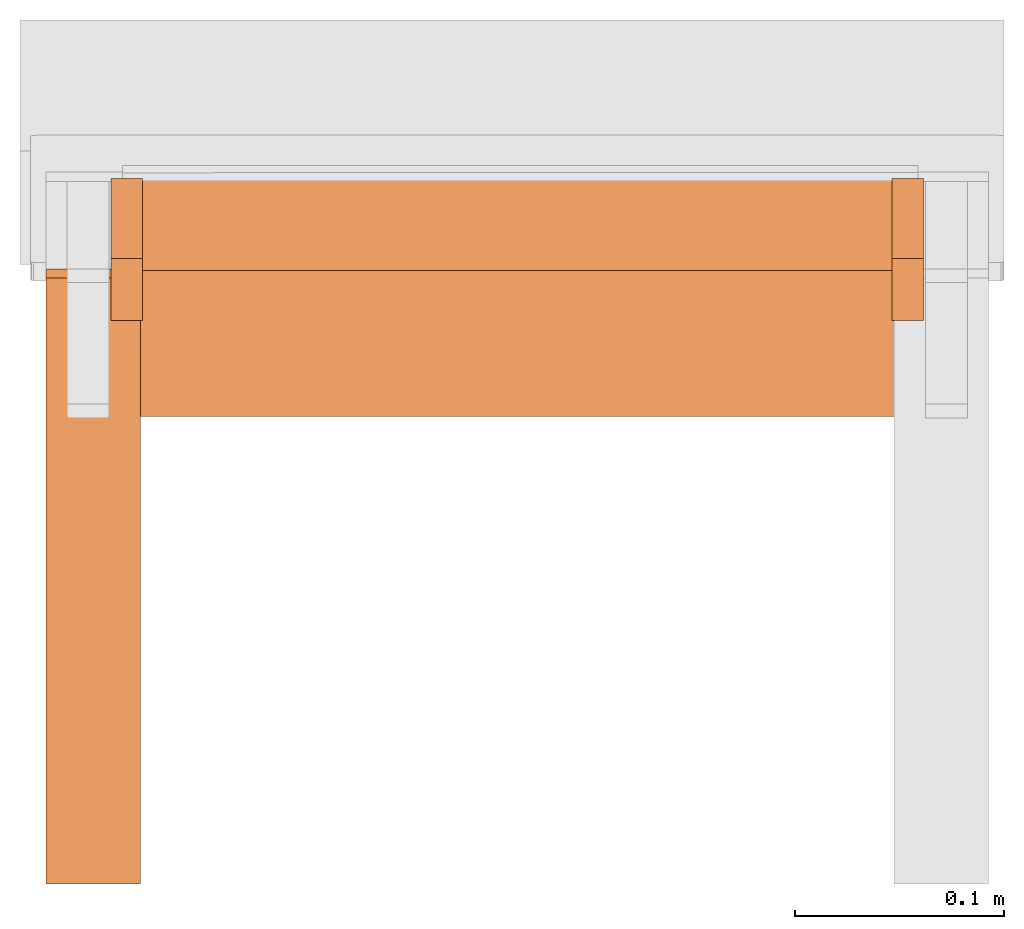
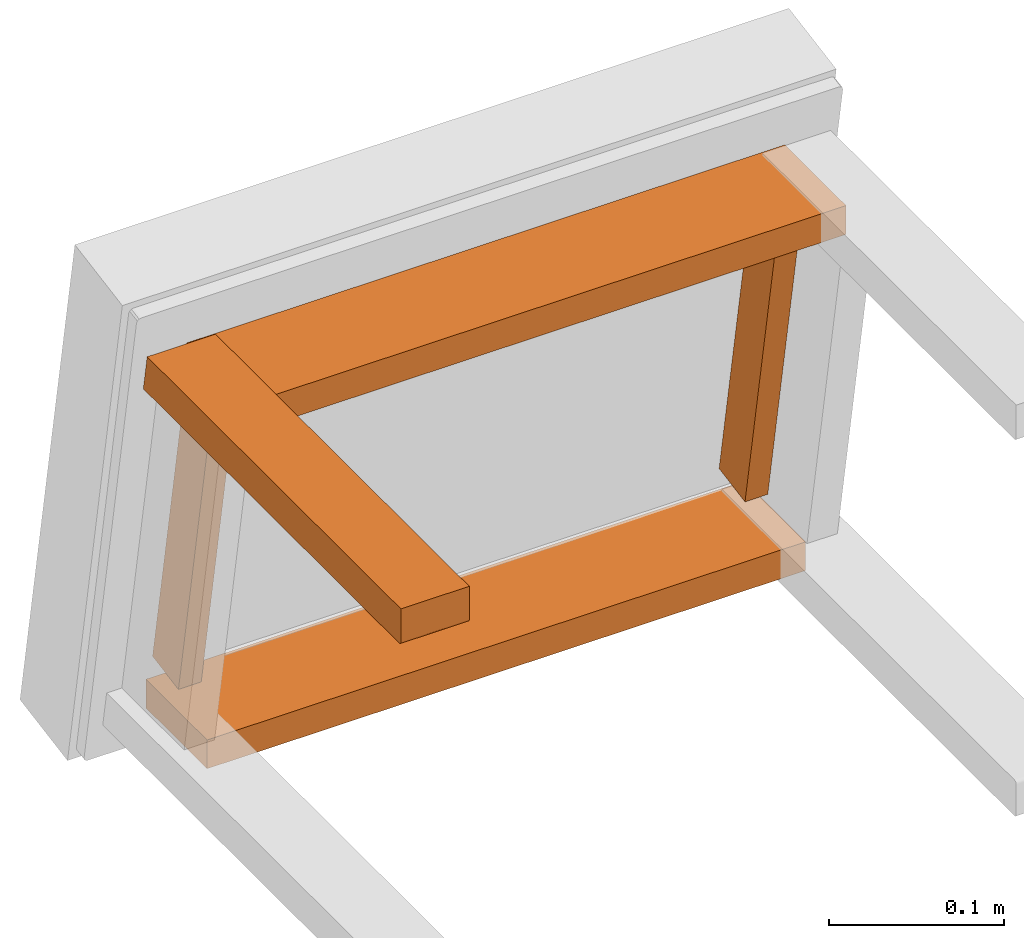
# One storey, part 1 of 5: 5 proxies, 1 element without a shape of its own.
"""IFC2X3 building model written with IfcOpenShell, lengths in metres."""

from ifc_helpers import new_model, si_unit, direction, origin_with_axes, place, context, project, spatial, faceted_brep, source, transform, mapped, element, aggregate, save


model = new_model("IFC2X3")

# Units and contexts
model_context = context("Model", 3, precision=1e-06, world=origin_with_axes(), true_north=direction((0.0, 1.0, 0.0)))
ifc_project = project(units=[si_unit("LENGTHUNIT", "METRE"), si_unit("AREAUNIT", "SQUARE_METRE"), si_unit("VOLUMEUNIT", "CUBIC_METRE")], contexts=[model_context])

# Site, building, storey
site_placement = place(None, origin_with_axes())
site = spatial("IfcSite", under=ifc_project, at=site_placement, CompositionType="ELEMENT")
building_placement = place(site_placement, origin_with_axes())
building = spatial("IfcBuilding", under=site, at=building_placement, Name="Default Building", CompositionType="ELEMENT")
storey_placement = place(building_placement, origin_with_axes())
storey = spatial("IfcBuildingStorey", under=building, at=storey_placement, Name="Default Storey", CompositionType="ELEMENT", Elevation=0.0)

# Assembly, proxies
assembly_placement = place(storey_placement, origin_with_axes())
assembly = element("IfcElementAssembly", 1, at=assembly_placement, inside=storey, Name="Pan H-68-037-A-REV reduced", ObjectType="Pan H-68-037-A-REV reduced", AssemblyPlace="NOTDEFINED", PredefinedType="NOTDEFINED")
shared_shape_1 = source(origin_with_axes(), model_context, "Body", "Brep", [
    faceted_brep([(0.19699999690055847, -0.08120664209127426, 0.25200098752975464), (0.19699999690055847, -0.08120664209127426, 0.2720009982585907), (-0.19699999690055847, -0.08120664209127426, 0.25200098752975464), (-0.19699999690055847, -0.08120664209127426, 0.25200098752975464), (0.19699999690055847, -0.08120664209127426, 0.2720009982585907), (-0.19699999690055847, -0.08120664209127426, 0.2720009982585907), (0.19699999690055847, -0.011398392729461193, 0.25200098752975464), (0.19699999690055847, -0.08120664209127426, 0.25200098752975464), (-0.19699999690055847, -0.011398392729461193, 0.25200098752975464), (-0.19699999690055847, -0.011398392729461193, 0.25200098752975464), (0.19699999690055847, -0.08120664209127426, 0.25200098752975464), (-0.19699999690055847, -0.08120664209127426, 0.25200098752975464), (0.19699999690055847, -0.011398392729461193, 0.2720009982585907), (0.19699999690055847, -0.011398392729461193, 0.25200098752975464), (-0.19699999690055847, -0.011398392729461193, 0.2720009982585907), (-0.19699999690055847, -0.011398392729461193, 0.2720009982585907), (0.19699999690055847, -0.011398392729461193, 0.25200098752975464), (-0.19699999690055847, -0.011398392729461193, 0.25200098752975464), (0.19699999690055847, -0.08120664209127426, 0.2720009982585907), (0.19699999690055847, -0.011398392729461193, 0.2720009982585907), (-0.19699999690055847, -0.08120664209127426, 0.2720009982585907), (-0.19699999690055847, -0.08120664209127426, 0.2720009982585907), (0.19699999690055847, -0.011398392729461193, 0.2720009982585907), (-0.19699999690055847, -0.011398392729461193, 0.2720009982585907), (0.19699999690055847, -0.011398392729461193, 0.25200098752975464), (0.19699999690055847, -0.011398392729461193, 0.2720009982585907), (0.19699999690055847, -0.08120664209127426, 0.25200098752975464), (0.19699999690055847, -0.08120664209127426, 0.25200098752975464), (0.19699999690055847, -0.011398392729461193, 0.2720009982585907), (0.19699999690055847, -0.08120664209127426, 0.2720009982585907), (-0.19699999690055847, -0.011398392729461193, 0.2720009982585907), (-0.19699999690055847, -0.011398392729461193, 0.25200098752975464), (-0.19699999690055847, -0.08120664209127426, 0.2720009982585907), (-0.19699999690055847, -0.08120664209127426, 0.2720009982585907), (-0.19699999690055847, -0.011398392729461193, 0.25200098752975464), (-0.19699999690055847, -0.08120664209127426, 0.25200098752975464)], [[[0, 1, 2]], [[3, 4, 5]], [[6, 7, 8]], [[9, 10, 11]], [[12, 13, 14]], [[15, 16, 17]], [[18, 19, 20]], [[21, 22, 23]], [[24, 25, 26]], [[27, 28, 29]], [[30, 31, 32]], [[33, 34, 35]]]),
])
proxy_1_placement = place(assembly_placement, origin_with_axes())
proxy_1 = element("IfcBuildingElementProxy", 2, at=proxy_1_placement, Name="9", ObjectType="9", CompositionType="ELEMENT", context=model_context, shape_type="MappedRepresentation", body=[
    mapped(shared_shape_1, transform((0.0, 0.0, 0.0), scale=1.0)),
])
shared_shape_2 = source(origin_with_axes(), model_context, "Body", "Brep", [
    faceted_brep([(-0.19699999690055847, -0.03500000014901161, 0.009999999776482582), (-0.19699999690055847, -0.03500000014901161, -0.009999999776482582), (0.19699999690055847, -0.03500000014901161, 0.009999999776482582), (0.19699999690055847, -0.03500000014901161, 0.009999999776482582), (-0.19699999690055847, -0.03500000014901161, -0.009999999776482582), (0.19699999690055847, -0.03500000014901161, -0.009999999776482582), (-0.19699999690055847, 0.03480824455618858, 0.009999999776482582), (-0.19699999690055847, -0.03500000014901161, 0.009999999776482582), (0.19699999690055847, 0.03480824455618858, 0.009999999776482582), (0.19699999690055847, 0.03480824455618858, 0.009999999776482582), (-0.19699999690055847, -0.03500000014901161, 0.009999999776482582), (0.19699999690055847, -0.03500000014901161, 0.009999999776482582), (-0.19699999690055847, 0.03480824455618858, -0.009999999776482582), (-0.19699999690055847, 0.03480824455618858, 0.009999999776482582), (0.19699999690055847, 0.03480824455618858, -0.009999999776482582), (0.19699999690055847, 0.03480824455618858, -0.009999999776482582), (-0.19699999690055847, 0.03480824455618858, 0.009999999776482582), (0.19699999690055847, 0.03480824455618858, 0.009999999776482582), (-0.19699999690055847, -0.03500000014901161, -0.009999999776482582), (-0.19699999690055847, 0.03480824455618858, -0.009999999776482582), (0.19699999690055847, -0.03500000014901161, -0.009999999776482582), (0.19699999690055847, -0.03500000014901161, -0.009999999776482582), (-0.19699999690055847, 0.03480824455618858, -0.009999999776482582), (0.19699999690055847, 0.03480824455618858, -0.009999999776482582), (-0.19699999690055847, 0.03480824455618858, 0.009999999776482582), (-0.19699999690055847, 0.03480824455618858, -0.009999999776482582), (-0.19699999690055847, -0.03500000014901161, 0.009999999776482582), (-0.19699999690055847, -0.03500000014901161, 0.009999999776482582), (-0.19699999690055847, 0.03480824455618858, -0.009999999776482582), (-0.19699999690055847, -0.03500000014901161, -0.009999999776482582), (0.19699999690055847, 0.03480824455618858, -0.009999999776482582), (0.19699999690055847, 0.03480824455618858, 0.009999999776482582), (0.19699999690055847, -0.03500000014901161, -0.009999999776482582), (0.19699999690055847, -0.03500000014901161, -0.009999999776482582), (0.19699999690055847, 0.03480824455618858, 0.009999999776482582), (0.19699999690055847, -0.03500000014901161, 0.009999999776482582)], [[[0, 1, 2]], [[3, 4, 5]], [[6, 7, 8]], [[9, 10, 11]], [[12, 13, 14]], [[15, 16, 17]], [[18, 19, 20]], [[21, 22, 23]], [[24, 25, 26]], [[27, 28, 29]], [[30, 31, 32]], [[33, 34, 35]]]),
])
proxy_2_placement = place(assembly_placement, origin_with_axes())
proxy_2 = element("IfcBuildingElementProxy", 3, at=proxy_2_placement, Name="10", ObjectType="10", CompositionType="ELEMENT", context=model_context, shape_type="MappedRepresentation", body=[
    mapped(shared_shape_2, transform((0.0, 0.0, 0.0), scale=1.0)),
])
shared_shape_3 = source(origin_with_axes(), model_context, "Body", "Brep", [
    faceted_brep([(0.17898231744766235, 0.002902057720348239, 0.021152222529053688), (0.1939823180437088, 0.002902057720348239, 0.021152222529053688), (0.17898231744766235, -0.035300541669130325, 0.2378099262714386), (0.17898231744766235, -0.035300541669130325, 0.2378099262714386), (0.1939823180437088, 0.002902057720348239, 0.021152222529053688), (0.1939823180437088, -0.035300541669130325, 0.2378099262714386), (0.17898231744766235, 0.03244629129767418, 0.02636166848242283), (0.17898231744766235, 0.002902057720348239, 0.021152222529053688), (0.17898231744766235, -0.005756308790296316, 0.24301937222480774), (0.17898231744766235, -0.005756308790296316, 0.24301937222480774), (0.17898231744766235, 0.002902057720348239, 0.021152222529053688), (0.17898231744766235, -0.035300541669130325, 0.2378099262714386), (0.1939823180437088, 0.03244629129767418, 0.02636166848242283), (0.17898231744766235, 0.03244629129767418, 0.02636166848242283), (0.1939823180437088, -0.005756308790296316, 0.24301937222480774), (0.1939823180437088, -0.005756308790296316, 0.24301937222480774), (0.17898231744766235, 0.03244629129767418, 0.02636166848242283), (0.17898231744766235, -0.005756308790296316, 0.24301937222480774), (0.1939823180437088, 0.002902057720348239, 0.021152222529053688), (0.1939823180437088, 0.03244629129767418, 0.02636166848242283), (0.1939823180437088, -0.035300541669130325, 0.2378099262714386), (0.1939823180437088, -0.035300541669130325, 0.2378099262714386), (0.1939823180437088, 0.03244629129767418, 0.02636166848242283), (0.1939823180437088, -0.005756308790296316, 0.24301937222480774), (0.17898231744766235, 0.03244629129767418, 0.02636166848242283), (0.1939823180437088, 0.03244629129767418, 0.02636166848242283), (0.17898231744766235, 0.002902057720348239, 0.021152222529053688), (0.17898231744766235, 0.002902057720348239, 0.021152222529053688), (0.1939823180437088, 0.03244629129767418, 0.02636166848242283), (0.1939823180437088, 0.002902057720348239, 0.021152222529053688), (0.1939823180437088, -0.005756308790296316, 0.24301937222480774), (0.17898231744766235, -0.005756308790296316, 0.24301937222480774), (0.1939823180437088, -0.035300541669130325, 0.2378099262714386), (0.1939823180437088, -0.035300541669130325, 0.2378099262714386), (0.17898231744766235, -0.005756308790296316, 0.24301937222480774), (0.17898231744766235, -0.035300541669130325, 0.2378099262714386)], [[[0, 1, 2]], [[3, 4, 5]], [[6, 7, 8]], [[9, 10, 11]], [[12, 13, 14]], [[15, 16, 17]], [[18, 19, 20]], [[21, 22, 23]], [[24, 25, 26]], [[27, 28, 29]], [[30, 31, 32]], [[33, 34, 35]]]),
])
proxy_3_placement = place(assembly_placement, origin_with_axes())
proxy_3 = element("IfcBuildingElementProxy", 4, at=proxy_3_placement, Name="11", ObjectType="11", CompositionType="ELEMENT", context=model_context, shape_type="MappedRepresentation", body=[
    mapped(shared_shape_3, transform((0.0, 0.0, 0.0), scale=1.0)),
])
shared_shape_4 = source(origin_with_axes(), model_context, "Body", "Brep", [
    faceted_brep([(-0.1939823180437088, 0.002902057720348239, 0.021152222529053688), (-0.17898231744766235, 0.002902057720348239, 0.021152222529053688), (-0.1939823180437088, -0.035300541669130325, 0.2378099262714386), (-0.1939823180437088, -0.035300541669130325, 0.2378099262714386), (-0.17898231744766235, 0.002902057720348239, 0.021152222529053688), (-0.17898231744766235, -0.035300541669130325, 0.2378099262714386), (-0.1939823180437088, 0.03244629129767418, 0.02636166848242283), (-0.1939823180437088, 0.002902057720348239, 0.021152222529053688), (-0.1939823180437088, -0.005756308790296316, 0.24301937222480774), (-0.1939823180437088, -0.005756308790296316, 0.24301937222480774), (-0.1939823180437088, 0.002902057720348239, 0.021152222529053688), (-0.1939823180437088, -0.035300541669130325, 0.2378099262714386), (-0.17898231744766235, 0.03244629129767418, 0.02636166848242283), (-0.1939823180437088, 0.03244629129767418, 0.02636166848242283), (-0.17898231744766235, -0.005756308790296316, 0.24301937222480774), (-0.17898231744766235, -0.005756308790296316, 0.24301937222480774), (-0.1939823180437088, 0.03244629129767418, 0.02636166848242283), (-0.1939823180437088, -0.005756308790296316, 0.24301937222480774), (-0.17898231744766235, 0.002902057720348239, 0.021152222529053688), (-0.17898231744766235, 0.03244629129767418, 0.02636166848242283), (-0.17898231744766235, -0.035300541669130325, 0.2378099262714386), (-0.17898231744766235, -0.035300541669130325, 0.2378099262714386), (-0.17898231744766235, 0.03244629129767418, 0.02636166848242283), (-0.17898231744766235, -0.005756308790296316, 0.24301937222480774), (-0.1939823180437088, 0.03244629129767418, 0.02636166848242283), (-0.17898231744766235, 0.03244629129767418, 0.02636166848242283), (-0.1939823180437088, 0.002902057720348239, 0.021152222529053688), (-0.1939823180437088, 0.002902057720348239, 0.021152222529053688), (-0.17898231744766235, 0.03244629129767418, 0.02636166848242283), (-0.17898231744766235, 0.002902057720348239, 0.021152222529053688), (-0.17898231744766235, -0.005756308790296316, 0.24301937222480774), (-0.1939823180437088, -0.005756308790296316, 0.24301937222480774), (-0.17898231744766235, -0.035300541669130325, 0.2378099262714386), (-0.17898231744766235, -0.035300541669130325, 0.2378099262714386), (-0.1939823180437088, -0.005756308790296316, 0.24301937222480774), (-0.1939823180437088, -0.035300541669130325, 0.2378099262714386)], [[[0, 1, 2]], [[3, 4, 5]], [[6, 7, 8]], [[9, 10, 11]], [[12, 13, 14]], [[15, 16, 17]], [[18, 19, 20]], [[21, 22, 23]], [[24, 25, 26]], [[27, 28, 29]], [[30, 31, 32]], [[33, 34, 35]]]),
])
proxy_4_placement = place(assembly_placement, origin_with_axes())
proxy_4 = element("IfcBuildingElementProxy", 5, at=proxy_4_placement, Name="12", ObjectType="12", CompositionType="ELEMENT", context=model_context, shape_type="MappedRepresentation", body=[
    mapped(shared_shape_4, transform((0.0, 0.0, 0.0), scale=1.0)),
])
shared_shape_5 = source(origin_with_axes(), model_context, "Body", "Brep", [
    faceted_brep([(-0.22499999403953552, -0.014805259183049202, 0.27250099182128906), (-0.22499999403953552, -0.015157913789153099, 0.2745009958744049), (-0.18000000715255737, -0.014805259183049202, 0.27250099182128906), (-0.18000000715255737, -0.014805259183049202, 0.27250099182128906), (-0.22499999403953552, -0.015157913789153099, 0.2745009958744049), (-0.18000000715255737, -0.015157913789153099, 0.2745009958744049), (-0.22499999403953552, -0.015157913789153099, 0.2745009958744049), (-0.22499999403953552, -0.09570664912462234, 0.2745009958744049), (-0.18000000715255737, -0.015157913789153099, 0.2745009958744049), (-0.18000000715255737, -0.015157913789153099, 0.2745009958744049), (-0.22499999403953552, -0.09570664912462234, 0.2745009958744049), (-0.18000000715255737, -0.09570664912462234, 0.2745009958744049), (-0.22499999403953552, -0.09570664912462234, 0.2745009958744049), (-0.22499999403953552, -0.3045358955860138, 0.2745009958744049), (-0.18000000715255737, -0.09570664912462234, 0.2745009958744049), (-0.18000000715255737, -0.09570664912462234, 0.2745009958744049), (-0.22499999403953552, -0.3045358955860138, 0.2745009958744049), (-0.18000000715255737, -0.3045358955860138, 0.2745009958744049), (-0.22499999403953552, -0.3045358955860138, 0.2745009958744049), (-0.22499999403953552, -0.3045358955860138, 0.2515009939670563), (-0.18000000715255737, -0.3045358955860138, 0.2745009958744049), (-0.18000000715255737, -0.3045358955860138, 0.2745009958744049), (-0.22499999403953552, -0.3045358955860138, 0.2515009939670563), (-0.18000000715255737, -0.3045358955860138, 0.2515009939670563), (-0.22499999403953552, -0.30253592133522034, 0.24950098991394043), (-0.18000000715255737, -0.30253592133522034, 0.24950098991394043), (-0.18000000715255737, -0.3030535578727722, 0.2495691329240799), (-0.22499999403953552, -0.30253592133522034, 0.24950098991394043), (-0.18000000715255737, -0.3030535578727722, 0.2495691329240799), (-0.22499999403953552, -0.3030535578727722, 0.2495691329240799), (-0.22499999403953552, -0.3030535578727722, 0.2495691329240799), (-0.18000000715255737, -0.3030535578727722, 0.2495691329240799), (-0.18000000715255737, -0.30353590846061707, 0.2497689425945282), (-0.22499999403953552, -0.3030535578727722, 0.2495691329240799), (-0.18000000715255737, -0.30353590846061707, 0.2497689425945282), (-0.22499999403953552, -0.30353590846061707, 0.2497689425945282), (-0.22499999403953552, -0.30353590846061707, 0.2497689425945282), (-0.18000000715255737, -0.30353590846061707, 0.2497689425945282), (-0.18000000715255737, -0.30395013093948364, 0.25008678436279297), (-0.22499999403953552, -0.30353590846061707, 0.2497689425945282), (-0.18000000715255737, -0.30395013093948364, 0.25008678436279297), (-0.22499999403953552, -0.30395013093948364, 0.25008678436279297), (-0.22499999403953552, -0.30395013093948364, 0.25008678436279297), (-0.18000000715255737, -0.30395013093948364, 0.25008678436279297), (-0.18000000715255737, -0.3042679727077484, 0.25050097703933716), (-0.22499999403953552, -0.30395013093948364, 0.25008678436279297), (-0.18000000715255737, -0.3042679727077484, 0.25050097703933716), (-0.22499999403953552, -0.3042679727077484, 0.25050097703933716), (-0.22499999403953552, -0.3042679727077484, 0.25050097703933716), (-0.18000000715255737, -0.3042679727077484, 0.25050097703933716), (-0.18000000715255737, -0.3044677674770355, 0.2509833574295044), (-0.22499999403953552, -0.3042679727077484, 0.25050097703933716), (-0.18000000715255737, -0.3044677674770355, 0.2509833574295044), (-0.22499999403953552, -0.3044677674770355, 0.2509833574295044), (-0.22499999403953552, -0.3044677674770355, 0.2509833574295044), (-0.18000000715255737, -0.3044677674770355, 0.2509833574295044), (-0.18000000715255737, -0.3045358955860138, 0.2515009939670563), (-0.22499999403953552, -0.3044677674770355, 0.2509833574295044), (-0.18000000715255737, -0.3045358955860138, 0.2515009939670563), (-0.22499999403953552, -0.3045358955860138, 0.2515009939670563), (-0.22499999403953552, -0.30253592133522034, 0.24950098991394043), (-0.22499999403953552, -0.09570664912462234, 0.24950098991394043), (-0.18000000715255737, -0.30253592133522034, 0.24950098991394043), (-0.18000000715255737, -0.30253592133522034, 0.24950098991394043), (-0.22499999403953552, -0.09570664912462234, 0.24950098991394043), (-0.18000000715255737, -0.09570664912462234, 0.24950098991394043), (-0.22499999403953552, -0.09570664912462234, 0.24950098991394043), (-0.22499999403953552, -0.010749738663434982, 0.24950098991394043), (-0.18000000715255737, -0.09570664912462234, 0.24950098991394043), (-0.18000000715255737, -0.09570664912462234, 0.24950098991394043), (-0.22499999403953552, -0.010749738663434982, 0.24950098991394043), (-0.18000000715255737, -0.010749738663434982, 0.24950098991394043), (-0.22499999403953552, -0.010749738663434982, 0.24950098991394043), (-0.22499999403953552, -0.011102392338216305, 0.2515009939670563), (-0.18000000715255737, -0.010749738663434982, 0.24950098991394043), (-0.18000000715255737, -0.010749738663434982, 0.24950098991394043), (-0.22499999403953552, -0.011102392338216305, 0.2515009939670563), (-0.18000000715255737, -0.011102392338216305, 0.2515009939670563), (-0.22499999403953552, -0.011102392338216305, 0.2515009939670563), (-0.22499999403953552, -0.014805259183049202, 0.27250099182128906), (-0.18000000715255737, -0.011102392338216305, 0.2515009939670563), (-0.18000000715255737, -0.011102392338216305, 0.2515009939670563), (-0.22499999403953552, -0.014805259183049202, 0.27250099182128906), (-0.18000000715255737, -0.014805259183049202, 0.27250099182128906), (-0.22499999403953552, -0.011102392338216305, 0.2515009939670563), (-0.22499999403953552, -0.010749738663434982, 0.24950098991394043), (-0.22499999403953552, -0.09570664912462234, 0.24950098991394043), (-0.22499999403953552, -0.011102392338216305, 0.2515009939670563), (-0.22499999403953552, -0.09570664912462234, 0.24950098991394043), (-0.22499999403953552, -0.014805259183049202, 0.27250099182128906), (-0.22499999403953552, -0.015157913789153099, 0.2745009958744049), (-0.22499999403953552, -0.014805259183049202, 0.27250099182128906), (-0.22499999403953552, -0.09570664912462234, 0.2745009958744049), (-0.22499999403953552, -0.09570664912462234, 0.2745009958744049), (-0.22499999403953552, -0.014805259183049202, 0.27250099182128906), (-0.22499999403953552, -0.09570664912462234, 0.24950098991394043), (-0.22499999403953552, -0.09570664912462234, 0.2745009958744049), (-0.22499999403953552, -0.09570664912462234, 0.24950098991394043), (-0.22499999403953552, -0.3045358955860138, 0.2745009958744049), (-0.22499999403953552, -0.3045358955860138, 0.2745009958744049), (-0.22499999403953552, -0.09570664912462234, 0.24950098991394043), (-0.22499999403953552, -0.30253592133522034, 0.24950098991394043), (-0.22499999403953552, -0.3045358955860138, 0.2745009958744049), (-0.22499999403953552, -0.30253592133522034, 0.24950098991394043), (-0.22499999403953552, -0.3045358955860138, 0.2515009939670563), (-0.22499999403953552, -0.3045358955860138, 0.2515009939670563), (-0.22499999403953552, -0.30253592133522034, 0.24950098991394043), (-0.22499999403953552, -0.3044677674770355, 0.2509833574295044), (-0.22499999403953552, -0.3030535578727722, 0.2495691329240799), (-0.22499999403953552, -0.30353590846061707, 0.2497689425945282), (-0.22499999403953552, -0.30395013093948364, 0.25008678436279297), (-0.22499999403953552, -0.3030535578727722, 0.2495691329240799), (-0.22499999403953552, -0.30395013093948364, 0.25008678436279297), (-0.22499999403953552, -0.30253592133522034, 0.24950098991394043), (-0.22499999403953552, -0.30253592133522034, 0.24950098991394043), (-0.22499999403953552, -0.30395013093948364, 0.25008678436279297), (-0.22499999403953552, -0.3042679727077484, 0.25050097703933716), (-0.22499999403953552, -0.30253592133522034, 0.24950098991394043), (-0.22499999403953552, -0.3042679727077484, 0.25050097703933716), (-0.22499999403953552, -0.3044677674770355, 0.2509833574295044), (-0.18000000715255737, -0.014805259183049202, 0.27250099182128906), (-0.18000000715255737, -0.015157913789153099, 0.2745009958744049), (-0.18000000715255737, -0.09570664912462234, 0.2745009958744049), (-0.18000000715255737, -0.09570664912462234, 0.24950098991394043), (-0.18000000715255737, -0.010749738663434982, 0.24950098991394043), (-0.18000000715255737, -0.011102392338216305, 0.2515009939670563), (-0.18000000715255737, -0.3030535578727722, 0.2495691329240799), (-0.18000000715255737, -0.30253592133522034, 0.24950098991394043), (-0.18000000715255737, -0.3045358955860138, 0.2515009939670563), (-0.18000000715255737, -0.011102392338216305, 0.2515009939670563), (-0.18000000715255737, -0.014805259183049202, 0.27250099182128906), (-0.18000000715255737, -0.09570664912462234, 0.24950098991394043), (-0.18000000715255737, -0.09570664912462234, 0.24950098991394043), (-0.18000000715255737, -0.014805259183049202, 0.27250099182128906), (-0.18000000715255737, -0.09570664912462234, 0.2745009958744049), (-0.18000000715255737, -0.09570664912462234, 0.24950098991394043), (-0.18000000715255737, -0.09570664912462234, 0.2745009958744049), (-0.18000000715255737, -0.30253592133522034, 0.24950098991394043), (-0.18000000715255737, -0.30253592133522034, 0.24950098991394043), (-0.18000000715255737, -0.09570664912462234, 0.2745009958744049), (-0.18000000715255737, -0.3045358955860138, 0.2745009958744049), (-0.18000000715255737, -0.30253592133522034, 0.24950098991394043), (-0.18000000715255737, -0.3045358955860138, 0.2745009958744049), (-0.18000000715255737, -0.3045358955860138, 0.2515009939670563), (-0.18000000715255737, -0.3044677674770355, 0.2509833574295044), (-0.18000000715255737, -0.3042679727077484, 0.25050097703933716), (-0.18000000715255737, -0.30395013093948364, 0.25008678436279297), (-0.18000000715255737, -0.3044677674770355, 0.2509833574295044), (-0.18000000715255737, -0.30395013093948364, 0.25008678436279297), (-0.18000000715255737, -0.3045358955860138, 0.2515009939670563), (-0.18000000715255737, -0.3045358955860138, 0.2515009939670563), (-0.18000000715255737, -0.30395013093948364, 0.25008678436279297), (-0.18000000715255737, -0.30353590846061707, 0.2497689425945282), (-0.18000000715255737, -0.3045358955860138, 0.2515009939670563), (-0.18000000715255737, -0.30353590846061707, 0.2497689425945282), (-0.18000000715255737, -0.3030535578727722, 0.2495691329240799)], [[[0, 1, 2]], [[3, 4, 5]], [[6, 7, 8]], [[9, 10, 11]], [[12, 13, 14]], [[15, 16, 17]], [[18, 19, 20]], [[21, 22, 23]], [[24, 25, 26]], [[27, 28, 29]], [[30, 31, 32]], [[33, 34, 35]], [[36, 37, 38]], [[39, 40, 41]], [[42, 43, 44]], [[45, 46, 47]], [[48, 49, 50]], [[51, 52, 53]], [[54, 55, 56]], [[57, 58, 59]], [[60, 61, 62]], [[63, 64, 65]], [[66, 67, 68]], [[69, 70, 71]], [[72, 73, 74]], [[75, 76, 77]], [[78, 79, 80]], [[81, 82, 83]], [[84, 85, 86]], [[87, 88, 89]], [[90, 91, 92]], [[93, 94, 95]], [[96, 97, 98]], [[99, 100, 101]], [[102, 103, 104]], [[105, 106, 107]], [[108, 109, 110]], [[111, 112, 113]], [[114, 115, 116]], [[117, 118, 119]], [[120, 121, 122]], [[123, 124, 125]], [[126, 127, 128]], [[129, 130, 131]], [[132, 133, 134]], [[135, 136, 137]], [[138, 139, 140]], [[141, 142, 143]], [[144, 145, 146]], [[147, 148, 149]], [[150, 151, 152]], [[153, 154, 155]]]),
])
proxy_5_placement = place(assembly_placement, origin_with_axes())
proxy_5 = element("IfcBuildingElementProxy", 6, at=proxy_5_placement, Name="16", ObjectType="16", CompositionType="ELEMENT", context=model_context, shape_type="MappedRepresentation", body=[
    mapped(shared_shape_5, transform((0.0, 0.0, 0.0), scale=1.0)),
])
aggregate(assembly, [proxy_1, proxy_2, proxy_3, proxy_4, proxy_5])

save(model, "model.ifc")
